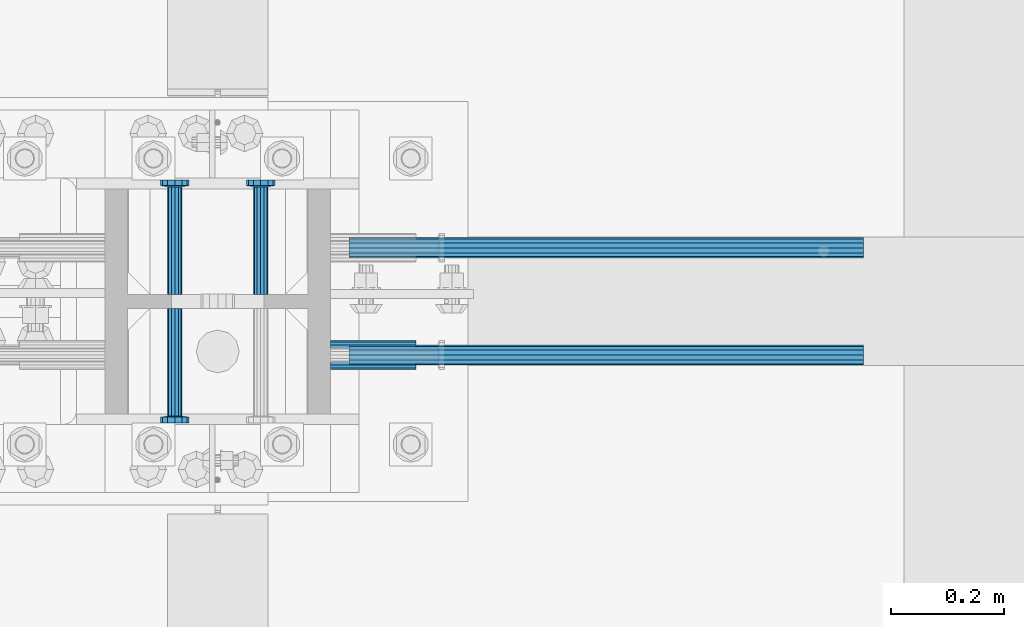
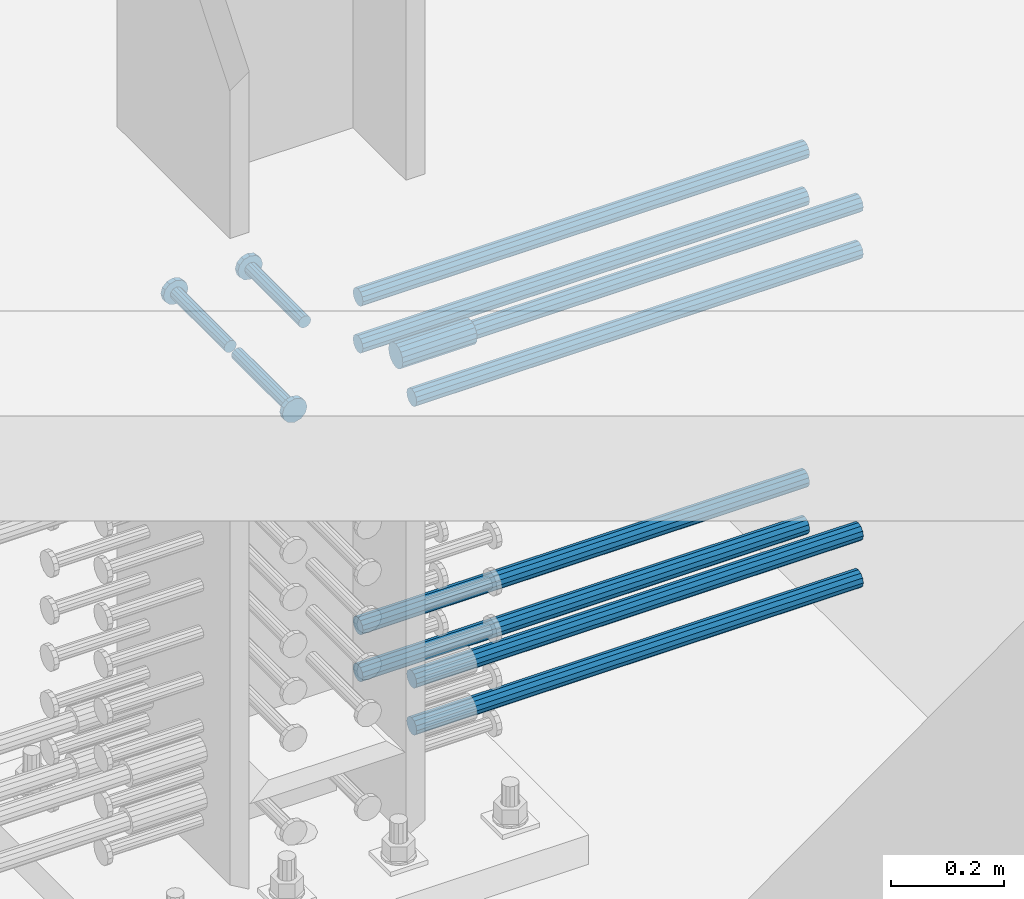
# One storey, part 1240 of 1763: 12 beams, 9 elements without a shape of their own.
"""IFC2X3 building model written with IfcOpenShell, lengths in millimetres."""

from ifc_helpers import new_model, si_unit, frame, origin_with_axes, place, context, subcontext, project, spatial, faceted_brep, material, type_object, element, aggregate, save


model = new_model("IFC2X3")

# Units and contexts
model_context = context("Model", 3, precision=1e-05, world=origin_with_axes())
body_context = subcontext(model_context, "Body", "Model", "MODEL_VIEW")
ifc_project = project(units=[si_unit("LENGTHUNIT", "METRE", prefix="MILLI"), si_unit("AREAUNIT", "SQUARE_METRE"), si_unit("VOLUMEUNIT", "CUBIC_METRE"), si_unit("MASSUNIT", "GRAM", prefix="KILO"), si_unit("TIMEUNIT", "SECOND"), si_unit("PLANEANGLEUNIT", "RADIAN"), si_unit("SOLIDANGLEUNIT", "STERADIAN"), si_unit("THERMODYNAMICTEMPERATUREUNIT", "DEGREE_CELSIUS"), si_unit("LUMINOUSINTENSITYUNIT", "LUMEN")], contexts=[model_context])

# Site, building, storey
site_placement = place(None, origin_with_axes())
site = spatial("IfcSite", under=ifc_project, at=site_placement, CompositionType="ELEMENT")
building_placement = place(site_placement, origin_with_axes())
building = spatial("IfcBuilding", under=site, at=building_placement, Name="Undefined", CompositionType="ELEMENT")
storey_placement = place(building_placement, origin_with_axes())
storey = spatial("IfcBuildingStorey", under=building, at=storey_placement, Name="Undefined", CompositionType="ELEMENT", Elevation=0.0)

# Assembly, beam
assembly_1_placement = place(storey_placement, origin_with_axes())
assembly_1 = element("IfcElementAssembly", 1, at=assembly_1_placement, inside=storey, Name="COLUMN", AssemblyPlace="NOTDEFINED", PredefinedType="RIGID_FRAME")
ifc_material_1 = material(Name="STEEL/A706-GR.80")
beam_type_1 = type_object("IfcBeamType", PredefinedType="NOTDEFINED")
beam_1_placement = place(assembly_1_placement, frame((-34749.812342359, 361.950000000843, 4876.80000000008), z_axis=(0.0, 0.0, 1.0), x_axis=(1.0, 0.0, 0.0)))
beam_1 = element("IfcBeam", 2, at=beam_1_placement, type_object=beam_type_1, material=ifc_material_1, Name="HALF COUPLER F", context=body_context, shape_type="Brep", body=[
    faceted_brep([(32.7659999999996, -8.95349999999962, -15.507916905568), (32.7659999999996, 0.0, -17.9070000000002), (32.7659999999996, 8.95349999999962, -15.507916905568), (32.7659999999996, 15.507916905568, -8.95350000000008), (32.7659999999996, 17.9069999999992, 0.0), (32.7659999999996, 15.507916905568, 8.95350000000008), (32.7659999999996, 8.95349999999962, 15.507916905568), (32.7659999999996, 0.0, 17.9070000000002), (32.7659999999996, -8.95349999999962, 15.507916905568), (32.7659999999996, -15.507916905568, 8.95350000000008), (32.7659999999996, -17.9069999999992, 0.0), (32.7659999999996, -15.507916905568, -8.95350000000008), (152.400103102711, -15.507916905568, 8.95350000000008), (152.400103102711, -8.95349999999962, 15.507916905568), (152.400103102711, -17.9069999999992, 0.0), (152.400103102711, -15.507916905568, -8.95350000000008), (152.400103102711, -8.95349999999962, -15.507916905568), (152.400103102711, 0.0, -17.9070000000002), (152.400103102711, 8.95349999999962, -15.507916905568), (152.400103102711, 15.507916905568, -8.95350000000008), (152.400103102711, 17.9069999999992, 0.0), (152.400103102711, 15.507916905568, 8.95350000000008), (152.400103102711, 8.95349999999962, 15.507916905568), (152.400103102711, 0.0, 17.9070000000002), (0.0, -23.466540125788, 9.72015918207308), (0.0, -17.9605122421381, 17.9605122421385), (0.0, -9.72015918207398, 23.4665401257867), (0.0, 0.0, 25.4000000000001), (0.0, 9.72015918207398, 23.4665401257867), (0.0, 17.9605122421381, 17.9605122421385), (0.0, 23.466540125788, 9.72015918207308), (0.0, 25.4000000000015, 0.0), (0.0, 23.466540125788, -9.72015918207308), (0.0, 17.9605122421381, -17.9605122421385), (0.0, 9.72015918207398, -23.4665401257867), (0.0, 0.0, -25.4000000000001), (0.0, -9.72015918207398, -23.4665401257867), (0.0, -17.9605122421381, -17.9605122421385), (0.0, -23.466540125788, -9.72015918207308), (0.0, -25.4000000000015, 0.0), (152.400103102711, -25.4000000000015, 0.0), (152.400103102711, -23.466540125788, 9.72015918207308), (152.400103102711, -17.9605122421381, 17.9605122421385), (152.400103102711, -9.72015918207398, 23.4665401257867), (152.400103102711, 0.0, 25.4000000000001), (152.400103102711, 9.72015918207398, 23.4665401257867), (152.400103102711, 17.9605122421381, 17.9605122421385), (152.400103102711, 23.466540125788, 9.72015918207308), (152.400103102711, 25.4000000000015, 0.0), (152.400103102711, 23.466540125788, -9.72015918207308), (152.400103102711, 17.9605122421381, -17.9605122421385), (152.400103102711, 9.72015918207398, -23.4665401257867), (152.400103102711, 0.0, -25.4000000000001), (152.400103102711, -9.72015918207398, -23.4665401257867), (152.400103102711, -17.9605122421381, -17.9605122421385), (152.400103102711, -23.466540125788, -9.72015918207308)], [[[0, 1, 2, 3, 4, 5, 6, 7, 8, 9, 10, 11]], [[12, 9, 8, 13]], [[14, 10, 9, 12]], [[15, 11, 10, 14]], [[16, 0, 11, 15]], [[17, 1, 0, 16]], [[18, 2, 1, 17]], [[19, 3, 2, 18]], [[20, 4, 3, 19]], [[21, 5, 4, 20]], [[22, 6, 5, 21]], [[23, 7, 6, 22]], [[13, 8, 7, 23]], [[24, 25, 26, 27, 28, 29, 30, 31, 32, 33, 34, 35, 36, 37, 38, 39]], [[24, 39, 40, 41]], [[25, 24, 41, 42]], [[26, 25, 42, 43]], [[27, 26, 43, 44]], [[28, 27, 44, 45]], [[29, 28, 45, 46]], [[30, 29, 46, 47]], [[31, 30, 47, 48]], [[32, 31, 48, 49]], [[33, 32, 49, 50]], [[34, 33, 50, 51]], [[35, 34, 51, 52]], [[36, 35, 52, 53]], [[37, 36, 53, 54]], [[38, 37, 54, 55]], [[39, 38, 55, 40]], [[54, 53, 52, 51, 50, 49, 48, 47, 46, 45, 44, 43, 42, 41, 40, 55], [21, 20, 19, 18, 17, 16, 15, 14, 12, 13, 23, 22]]]),
])

assembly_2_placement = place(storey_placement, origin_with_axes())
assembly_2 = element("IfcElementAssembly", 3, at=assembly_2_placement, inside=storey, Name="REBAR", AssemblyPlace="NOTDEFINED", PredefinedType="RIGID_FRAME")
beam_type_2 = type_object("IfcBeamType", Name="#11 REBAR", PredefinedType="NOTDEFINED")
beam_2_placement = place(assembly_2_placement, frame((-34717.0460129546, 361.949999998851, 4165.60000000003), z_axis=(0.0, 0.0, 1.0), x_axis=(1.0, 0.0, 0.0)))
beam_2 = element("IfcBeam", 4, at=beam_2_placement, type_object=beam_type_2, material=ifc_material_1, Name="REBAR", ObjectType="#11 REBAR", context=body_context, shape_type="Brep", body=[
    faceted_brep([(0.0, -17.9069999999992, 0.0), (0.0, -15.507916905568, -8.95349999999962), (914.400000001086, -15.507916905568, -8.95349999999962), (914.400000001086, -17.9069999999992, 0.0), (0.0, -8.95349999999962, -15.507916905568), (914.400000001086, -8.95349999999962, -15.507916905568), (0.0, 0.0, -17.9070000000002), (914.400000001086, 0.0, -17.9070000000002), (0.0, 8.95349999999962, -15.507916905568), (914.400000001086, 8.95349999999962, -15.507916905568), (0.0, 15.507916905568, -8.95349999999962), (914.400000001086, 15.507916905568, -8.95349999999962), (0.0, 17.9069999999992, 0.0), (914.400000001086, 17.9069999999992, 0.0), (0.0, 15.507916905568, 8.95349999999962), (914.400000001086, 15.507916905568, 8.95349999999962), (0.0, 8.95349999999962, 15.507916905568), (914.400000001086, 8.95349999999962, 15.507916905568), (0.0, 0.0, 17.9070000000002), (914.400000001086, 0.0, 17.9070000000002), (0.0, -8.95349999999962, 15.507916905568), (914.400000001086, -8.95349999999962, 15.507916905568), (0.0, -15.507916905568, 8.95349999999962), (914.400000001086, -15.507916905568, 8.95349999999962)], [[[0, 1, 2, 3]], [[1, 4, 5, 2]], [[4, 6, 7, 5]], [[6, 8, 9, 7]], [[8, 10, 11, 9]], [[10, 12, 13, 11]], [[12, 14, 15, 13]], [[14, 16, 17, 15]], [[16, 18, 19, 17]], [[18, 20, 21, 19]], [[20, 22, 23, 21]], [[22, 0, 3, 23]], [[5, 7, 9, 11, 13, 15, 17, 19, 21, 23, 3, 2]], [[22, 20, 18, 16, 14, 12, 10, 8, 6, 4, 1, 0]]]),
])
aggregate(assembly_2, [beam_2])

assembly_3_placement = place(storey_placement, origin_with_axes())
assembly_3 = element("IfcElementAssembly", 5, at=assembly_3_placement, inside=storey, Name="REBAR", AssemblyPlace="NOTDEFINED", PredefinedType="RIGID_FRAME")
beam_3_placement = place(assembly_3_placement, frame((-34717.0459442928, 552.449999998264, 4165.60000000003), z_axis=(0.0, 0.0, 1.0), x_axis=(1.0, 0.0, 0.0)))
beam_3 = element("IfcBeam", 6, at=beam_3_placement, type_object=beam_type_2, material=ifc_material_1, Name="REBAR", ObjectType="#11 REBAR", context=body_context, shape_type="Brep", body=[
    faceted_brep([(0.0, -17.9069999999992, 0.0), (0.0, -15.507916905568, -8.95349999999962), (914.400000001086, -15.507916905568, -8.95349999999962), (914.400000001086, -17.9069999999992, 0.0), (0.0, -8.95349999999962, -15.507916905568), (914.400000001086, -8.95349999999962, -15.507916905568), (0.0, 0.0, -17.9070000000002), (914.400000001086, 0.0, -17.9070000000002), (0.0, 8.95349999999962, -15.507916905568), (914.400000001086, 8.95349999999962, -15.507916905568), (0.0, 15.507916905568, -8.95349999999962), (914.400000001086, 15.507916905568, -8.95349999999962), (0.0, 17.9069999999992, 0.0), (914.400000001086, 17.9069999999992, 0.0), (0.0, 15.507916905568, 8.95349999999962), (914.400000001086, 15.507916905568, 8.95349999999962), (0.0, 8.95349999999962, 15.507916905568), (914.400000001086, 8.95349999999962, 15.507916905568), (0.0, 0.0, 17.9070000000002), (914.400000001086, 0.0, 17.9070000000002), (0.0, -8.95349999999962, 15.507916905568), (914.400000001086, -8.95349999999962, 15.507916905568), (0.0, -15.507916905568, 8.95349999999962), (914.400000001086, -15.507916905568, 8.95349999999962)], [[[0, 1, 2, 3]], [[1, 4, 5, 2]], [[4, 6, 7, 5]], [[6, 8, 9, 7]], [[8, 10, 11, 9]], [[10, 12, 13, 11]], [[12, 14, 15, 13]], [[14, 16, 17, 15]], [[16, 18, 19, 17]], [[18, 20, 21, 19]], [[20, 22, 23, 21]], [[22, 0, 3, 23]], [[5, 7, 9, 11, 13, 15, 17, 19, 21, 23, 3, 2]], [[22, 20, 18, 16, 14, 12, 10, 8, 6, 4, 1, 0]]]),
])
aggregate(assembly_3, [beam_3])

assembly_4_placement = place(storey_placement, origin_with_axes())
assembly_4 = element("IfcElementAssembly", 7, at=assembly_4_placement, inside=storey, Name="REBAR", AssemblyPlace="NOTDEFINED", PredefinedType="RIGID_FRAME")
beam_4_placement = place(assembly_4_placement, frame((-34717.0460129546, 361.949999998855, 4064.00000000003), z_axis=(0.0, 0.0, 1.0), x_axis=(1.0, 0.0, 0.0)))
beam_4 = element("IfcBeam", 8, at=beam_4_placement, type_object=beam_type_2, material=ifc_material_1, Name="REBAR", ObjectType="#11 REBAR", context=body_context, shape_type="Brep", body=[
    faceted_brep([(0.0, -17.9069999999992, 0.0), (0.0, -15.507916905568, -8.95349999999962), (914.400000001086, -15.507916905568, -8.95349999999962), (914.400000001086, -17.9069999999992, 0.0), (0.0, -8.95349999999962, -15.507916905568), (914.400000001086, -8.95349999999962, -15.507916905568), (0.0, 0.0, -17.9070000000002), (914.400000001086, 0.0, -17.9070000000002), (0.0, 8.95349999999962, -15.507916905568), (914.400000001086, 8.95349999999962, -15.507916905568), (0.0, 15.507916905568, -8.95349999999962), (914.400000001086, 15.507916905568, -8.95349999999962), (0.0, 17.9069999999992, 0.0), (914.400000001086, 17.9069999999992, 0.0), (0.0, 15.507916905568, 8.95349999999962), (914.400000001086, 15.507916905568, 8.95349999999962), (0.0, 8.95349999999962, 15.507916905568), (914.400000001086, 8.95349999999962, 15.507916905568), (0.0, 0.0, 17.9070000000002), (914.400000001086, 0.0, 17.9070000000002), (0.0, -8.95349999999962, 15.507916905568), (914.400000001086, -8.95349999999962, 15.507916905568), (0.0, -15.507916905568, 8.95349999999962), (914.400000001086, -15.507916905568, 8.95349999999962)], [[[0, 1, 2, 3]], [[1, 4, 5, 2]], [[4, 6, 7, 5]], [[6, 8, 9, 7]], [[8, 10, 11, 9]], [[10, 12, 13, 11]], [[12, 14, 15, 13]], [[14, 16, 17, 15]], [[16, 18, 19, 17]], [[18, 20, 21, 19]], [[20, 22, 23, 21]], [[22, 0, 3, 23]], [[5, 7, 9, 11, 13, 15, 17, 19, 21, 23, 3, 2]], [[22, 20, 18, 16, 14, 12, 10, 8, 6, 4, 1, 0]]]),
])
aggregate(assembly_4, [beam_4])

assembly_5_placement = place(storey_placement, origin_with_axes())
assembly_5 = element("IfcElementAssembly", 9, at=assembly_5_placement, inside=storey, Name="REBAR", AssemblyPlace="NOTDEFINED", PredefinedType="RIGID_FRAME")
beam_5_placement = place(assembly_5_placement, frame((-34717.0459442928, 552.449999998267, 4064.00000000003), z_axis=(0.0, 0.0, 1.0), x_axis=(1.0, 0.0, 0.0)))
beam_5 = element("IfcBeam", 10, at=beam_5_placement, type_object=beam_type_2, material=ifc_material_1, Name="REBAR", ObjectType="#11 REBAR", context=body_context, shape_type="Brep", body=[
    faceted_brep([(0.0, -17.9069999999992, 0.0), (0.0, -15.507916905568, -8.95349999999962), (914.400000001086, -15.507916905568, -8.95349999999962), (914.400000001086, -17.9069999999992, 0.0), (0.0, -8.95349999999962, -15.507916905568), (914.400000001086, -8.95349999999962, -15.507916905568), (0.0, 0.0, -17.9070000000002), (914.400000001086, 0.0, -17.9070000000002), (0.0, 8.95349999999962, -15.507916905568), (914.400000001086, 8.95349999999962, -15.507916905568), (0.0, 15.507916905568, -8.95349999999962), (914.400000001086, 15.507916905568, -8.95349999999962), (0.0, 17.9069999999992, 0.0), (914.400000001086, 17.9069999999992, 0.0), (0.0, 15.507916905568, 8.95349999999962), (914.400000001086, 15.507916905568, 8.95349999999962), (0.0, 8.95349999999962, 15.507916905568), (914.400000001086, 8.95349999999962, 15.507916905568), (0.0, 0.0, 17.9070000000002), (914.400000001086, 0.0, 17.9070000000002), (0.0, -8.95349999999962, 15.507916905568), (914.400000001086, -8.95349999999962, 15.507916905568), (0.0, -15.507916905568, 8.95349999999962), (914.400000001086, -15.507916905568, 8.95349999999962)], [[[0, 1, 2, 3]], [[1, 4, 5, 2]], [[4, 6, 7, 5]], [[6, 8, 9, 7]], [[8, 10, 11, 9]], [[10, 12, 13, 11]], [[12, 14, 15, 13]], [[14, 16, 17, 15]], [[16, 18, 19, 17]], [[18, 20, 21, 19]], [[20, 22, 23, 21]], [[22, 0, 3, 23]], [[5, 7, 9, 11, 13, 15, 17, 19, 21, 23, 3, 2]], [[22, 20, 18, 16, 14, 12, 10, 8, 6, 4, 1, 0]]]),
])
aggregate(assembly_5, [beam_5])

assembly_6_placement = place(storey_placement, origin_with_axes())
assembly_6 = element("IfcElementAssembly", 11, at=assembly_6_placement, inside=storey, Name="REBAR", AssemblyPlace="NOTDEFINED", PredefinedType="RIGID_FRAME")
beam_6_placement = place(assembly_6_placement, frame((-34717.0460816901, 361.949999998849, 4876.80000000009), z_axis=(0.0, 0.0, 1.0), x_axis=(1.0, 0.0, 0.0)))
beam_6 = element("IfcBeam", 12, at=beam_6_placement, type_object=beam_type_2, material=ifc_material_1, Name="REBAR", ObjectType="#11 REBAR", context=body_context, shape_type="Brep", body=[
    faceted_brep([(0.0, -17.9069999999992, 0.0), (0.0, -15.507916905568, -8.95349999999962), (914.400000001086, -15.507916905568, -8.95349999999962), (914.400000001086, -17.9069999999992, 0.0), (0.0, -8.95349999999962, -15.507916905568), (914.400000001086, -8.95349999999962, -15.507916905568), (0.0, 0.0, -17.9070000000002), (914.400000001086, 0.0, -17.9070000000002), (0.0, 8.95349999999962, -15.507916905568), (914.400000001086, 8.95349999999962, -15.507916905568), (0.0, 15.507916905568, -8.95349999999962), (914.400000001086, 15.507916905568, -8.95349999999962), (0.0, 17.9069999999992, 0.0), (914.400000001086, 17.9069999999992, 0.0), (0.0, 15.507916905568, 8.95349999999962), (914.400000001086, 15.507916905568, 8.95349999999962), (0.0, 8.95349999999962, 15.507916905568), (914.400000001086, 8.95349999999962, 15.507916905568), (0.0, 0.0, 17.9070000000002), (914.400000001086, 0.0, 17.9070000000002), (0.0, -8.95349999999962, 15.507916905568), (914.400000001086, -8.95349999999962, 15.507916905568), (0.0, -15.507916905568, 8.95349999999962), (914.400000001086, -15.507916905568, 8.95349999999962)], [[[0, 1, 2, 3]], [[1, 4, 5, 2]], [[4, 6, 7, 5]], [[6, 8, 9, 7]], [[8, 10, 11, 9]], [[10, 12, 13, 11]], [[12, 14, 15, 13]], [[14, 16, 17, 15]], [[16, 18, 19, 17]], [[18, 20, 21, 19]], [[20, 22, 23, 21]], [[22, 0, 3, 23]], [[5, 7, 9, 11, 13, 15, 17, 19, 21, 23, 3, 2]], [[22, 20, 18, 16, 14, 12, 10, 8, 6, 4, 1, 0]]]),
])
aggregate(assembly_6, [beam_6])

assembly_7_placement = place(storey_placement, origin_with_axes())
assembly_7 = element("IfcElementAssembly", 13, at=assembly_7_placement, inside=storey, Name="REBAR", AssemblyPlace="NOTDEFINED", PredefinedType="RIGID_FRAME")
beam_7_placement = place(assembly_7_placement, frame((-34717.0460130289, 552.449999998262, 4876.80000000009), z_axis=(0.0, 0.0, 1.0), x_axis=(1.0, 0.0, 0.0)))
beam_7 = element("IfcBeam", 14, at=beam_7_placement, type_object=beam_type_2, material=ifc_material_1, Name="REBAR", ObjectType="#11 REBAR", context=body_context, shape_type="Brep", body=[
    faceted_brep([(0.0, -17.9069999999992, 0.0), (0.0, -15.507916905568, -8.95349999999962), (914.400000001086, -15.507916905568, -8.95349999999962), (914.400000001086, -17.9069999999992, 0.0), (0.0, -8.95349999999962, -15.507916905568), (914.400000001086, -8.95349999999962, -15.507916905568), (0.0, 0.0, -17.9070000000002), (914.400000001086, 0.0, -17.9070000000002), (0.0, 8.95349999999962, -15.507916905568), (914.400000001086, 8.95349999999962, -15.507916905568), (0.0, 15.507916905568, -8.95349999999962), (914.400000001086, 15.507916905568, -8.95349999999962), (0.0, 17.9069999999992, 0.0), (914.400000001086, 17.9069999999992, 0.0), (0.0, 15.507916905568, 8.95349999999962), (914.400000001086, 15.507916905568, 8.95349999999962), (0.0, 8.95349999999962, 15.507916905568), (914.400000001086, 8.95349999999962, 15.507916905568), (0.0, 0.0, 17.9070000000002), (914.400000001086, 0.0, 17.9070000000002), (0.0, -8.95349999999962, 15.507916905568), (914.400000001086, -8.95349999999962, 15.507916905568), (0.0, -15.507916905568, 8.95349999999962), (914.400000001086, -15.507916905568, 8.95349999999962)], [[[0, 1, 2, 3]], [[1, 4, 5, 2]], [[4, 6, 7, 5]], [[6, 8, 9, 7]], [[8, 10, 11, 9]], [[10, 12, 13, 11]], [[12, 14, 15, 13]], [[14, 16, 17, 15]], [[16, 18, 19, 17]], [[18, 20, 21, 19]], [[20, 22, 23, 21]], [[22, 0, 3, 23]], [[5, 7, 9, 11, 13, 15, 17, 19, 21, 23, 3, 2]], [[22, 20, 18, 16, 14, 12, 10, 8, 6, 4, 1, 0]]]),
])
aggregate(assembly_7, [beam_7])

assembly_8_placement = place(storey_placement, origin_with_axes())
assembly_8 = element("IfcElementAssembly", 15, at=assembly_8_placement, inside=storey, Name="REBAR", AssemblyPlace="NOTDEFINED", PredefinedType="RIGID_FRAME")
beam_8_placement = place(assembly_8_placement, frame((-34717.0460816901, 361.949999998853, 4775.20000000009), z_axis=(0.0, 0.0, 1.0), x_axis=(1.0, 0.0, 0.0)))
beam_8 = element("IfcBeam", 16, at=beam_8_placement, type_object=beam_type_2, material=ifc_material_1, Name="REBAR", ObjectType="#11 REBAR", context=body_context, shape_type="Brep", body=[
    faceted_brep([(0.0, -17.9069999999992, 0.0), (0.0, -15.507916905568, -8.95349999999962), (914.400000001086, -15.507916905568, -8.95349999999962), (914.400000001086, -17.9069999999992, 0.0), (0.0, -8.95349999999962, -15.507916905568), (914.400000001086, -8.95349999999962, -15.507916905568), (0.0, 0.0, -17.9070000000002), (914.400000001086, 0.0, -17.9070000000002), (0.0, 8.95349999999962, -15.507916905568), (914.400000001086, 8.95349999999962, -15.507916905568), (0.0, 15.507916905568, -8.95349999999962), (914.400000001086, 15.507916905568, -8.95349999999962), (0.0, 17.9069999999992, 0.0), (914.400000001086, 17.9069999999992, 0.0), (0.0, 15.507916905568, 8.95349999999962), (914.400000001086, 15.507916905568, 8.95349999999962), (0.0, 8.95349999999962, 15.507916905568), (914.400000001086, 8.95349999999962, 15.507916905568), (0.0, 0.0, 17.9070000000002), (914.400000001086, 0.0, 17.9070000000002), (0.0, -8.95349999999962, 15.507916905568), (914.400000001086, -8.95349999999962, 15.507916905568), (0.0, -15.507916905568, 8.95349999999962), (914.400000001086, -15.507916905568, 8.95349999999962)], [[[0, 1, 2, 3]], [[1, 4, 5, 2]], [[4, 6, 7, 5]], [[6, 8, 9, 7]], [[8, 10, 11, 9]], [[10, 12, 13, 11]], [[12, 14, 15, 13]], [[14, 16, 17, 15]], [[16, 18, 19, 17]], [[18, 20, 21, 19]], [[20, 22, 23, 21]], [[22, 0, 3, 23]], [[5, 7, 9, 11, 13, 15, 17, 19, 21, 23, 3, 2]], [[22, 20, 18, 16, 14, 12, 10, 8, 6, 4, 1, 0]]]),
])
aggregate(assembly_8, [beam_8])

assembly_9_placement = place(storey_placement, origin_with_axes())
assembly_9 = element("IfcElementAssembly", 17, at=assembly_9_placement, inside=storey, Name="REBAR", AssemblyPlace="NOTDEFINED", PredefinedType="RIGID_FRAME")
beam_9_placement = place(assembly_9_placement, frame((-34717.0460130289, 552.449999998265, 4775.20000000009), z_axis=(0.0, 0.0, 1.0), x_axis=(1.0, 0.0, 0.0)))
beam_9 = element("IfcBeam", 18, at=beam_9_placement, type_object=beam_type_2, material=ifc_material_1, Name="REBAR", ObjectType="#11 REBAR", context=body_context, shape_type="Brep", body=[
    faceted_brep([(0.0, -17.9069999999992, 0.0), (0.0, -15.507916905568, -8.95349999999962), (914.400000001086, -15.507916905568, -8.95349999999962), (914.400000001086, -17.9069999999992, 0.0), (0.0, -8.95349999999962, -15.507916905568), (914.400000001086, -8.95349999999962, -15.507916905568), (0.0, 0.0, -17.9070000000002), (914.400000001086, 0.0, -17.9070000000002), (0.0, 8.95349999999962, -15.507916905568), (914.400000001086, 8.95349999999962, -15.507916905568), (0.0, 15.507916905568, -8.95349999999962), (914.400000001086, 15.507916905568, -8.95349999999962), (0.0, 17.9069999999992, 0.0), (914.400000001086, 17.9069999999992, 0.0), (0.0, 15.507916905568, 8.95349999999962), (914.400000001086, 15.507916905568, 8.95349999999962), (0.0, 8.95349999999962, 15.507916905568), (914.400000001086, 8.95349999999962, 15.507916905568), (0.0, 0.0, 17.9070000000002), (914.400000001086, 0.0, 17.9070000000002), (0.0, -8.95349999999962, 15.507916905568), (914.400000001086, -8.95349999999962, 15.507916905568), (0.0, -15.507916905568, 8.95349999999962), (914.400000001086, -15.507916905568, 8.95349999999962)], [[[0, 1, 2, 3]], [[1, 4, 5, 2]], [[4, 6, 7, 5]], [[6, 8, 9, 7]], [[8, 10, 11, 9]], [[10, 12, 13, 11]], [[12, 14, 15, 13]], [[14, 16, 17, 15]], [[16, 18, 19, 17]], [[18, 20, 21, 19]], [[20, 22, 23, 21]], [[22, 0, 3, 23]], [[5, 7, 9, 11, 13, 15, 17, 19, 21, 23, 3, 2]], [[22, 20, 18, 16, 14, 12, 10, 8, 6, 4, 1, 0]]]),
])
aggregate(assembly_9, [beam_9])

# Beam
ifc_material_2 = material(Name="STEEL/A108")
beam_type_3 = type_object("IfcBeamType", PredefinedType="NOTDEFINED")
beam_10_placement = place(assembly_1_placement, frame((-34873.6374118352, 469.899999999951, 4927.60000000008), z_axis=(1.0, 0.0, 0.0), x_axis=(0.0, 1.0, 0.0)))
beam_10 = element("IfcBeam", 19, at=beam_10_placement, type_object=beam_type_3, material=ifc_material_2, Name="HEADED STUD ANCHOR", context=body_context, shape_type="Brep", body=[
    faceted_brep([(0.0, -12.6999999999971, -1.81898940354586e-12), (3.63797880709171e-12, -11.0, -6.34999990463257), (191.00799999576, -11.0, -6.34999990454889), (191.007999995752, -12.6999998092651, 8.36735125631094e-11), (7.27595761418343e-12, -6.34999990463257, -11.0), (191.00799999576, -6.34999990463257, -10.9999999999163), (3.63797880709171e-12, 0.0, -12.6999998092651), (191.00799999576, 0.0, -12.6999998091815), (7.27595761418343e-12, 6.34999990463257, -11.0), (191.00799999576, 6.34999990463257, -10.9999999999163), (3.63797880709171e-12, 11.0, -6.34999990463257), (191.00799999576, 11.0, -6.34999990454889), (0.0, 12.6999999999971, -1.81898940354586e-12), (191.007999995752, 12.6999998092651, 8.36735125631094e-11), (0.0, 11.0, 6.34999990463257), (191.007999995752, 11.0, 6.34999990471624), (-3.63797880709171e-12, 6.34999990463257, 11.0), (191.007999995749, 6.34999990463257, 11.0000000000837), (-3.63797880709171e-12, 0.0, 12.6999998092651), (191.007999995749, 0.0, 12.6999998093488), (-3.63797880709171e-12, -6.34999990463257, 11.0), (191.007999995749, -6.34999990463257, 11.0000000000837), (0.0, -11.0, 6.34999990463257), (191.007999995752, -11.0, 6.34999990471624), (193.039999995715, -22.0, -12.6999998091796), (193.039999995708, -25.3999996185303, 8.54925019666553e-11), (193.039999995719, -12.6999998092651, -21.9999999999145), (193.039999995719, 0.0, -25.3999996184448), (193.039999995719, 12.6999998092651, -21.9999999999145), (193.039999995715, 22.0, -12.6999998091796), (193.039999995708, 25.3999996185303, 8.54925019666553e-11), (193.039999995704, 22.0, 12.6999998093506), (193.039999995701, 12.6999998092651, 22.0000000000855), (193.039999995697, 0.0, 25.3999996186158), (193.039999995701, -12.6999998092651, 22.0000000000855), (193.039999995704, -22.0, 12.6999998093506), (203.199999995486, -22.0, -12.6999998091742), (203.199999995482, -25.3999996185303, 9.09494701772928e-11), (203.199999995493, -12.6999998092651, -21.9999999999091), (203.199999995493, 0.0, -25.3999996184393), (203.199999995493, 12.6999998092651, -21.9999999999091), (203.199999995486, 22.0, -12.6999998091742), (203.199999995482, 25.3999996185303, 9.09494701772928e-11), (203.199999995479, 22.0, 12.6999998093561), (203.199999995475, 12.6999998092651, 22.0000000000909), (203.199999995471, 0.0, 25.3999996186212), (203.199999995475, -12.6999998092651, 22.0000000000909), (203.199999995479, -22.0, 12.6999998093561)], [[[0, 1, 2, 3]], [[1, 4, 5, 2]], [[4, 6, 7, 5]], [[6, 8, 9, 7]], [[8, 10, 11, 9]], [[10, 12, 13, 11]], [[12, 14, 15, 13]], [[14, 16, 17, 15]], [[16, 18, 19, 17]], [[18, 20, 21, 19]], [[20, 22, 23, 21]], [[22, 0, 3, 23]], [[22, 20, 18, 16, 14, 12, 10, 8, 6, 4, 1, 0]], [[3, 2, 24, 25]], [[2, 5, 26, 24]], [[5, 7, 27, 26]], [[7, 9, 28, 27]], [[9, 11, 29, 28]], [[11, 13, 30, 29]], [[13, 15, 31, 30]], [[15, 17, 32, 31]], [[17, 19, 33, 32]], [[19, 21, 34, 33]], [[21, 23, 35, 34]], [[23, 3, 25, 35]], [[25, 24, 36, 37]], [[24, 26, 38, 36]], [[26, 27, 39, 38]], [[27, 28, 40, 39]], [[28, 29, 41, 40]], [[29, 30, 42, 41]], [[30, 31, 43, 42]], [[31, 32, 44, 43]], [[32, 33, 45, 44]], [[33, 34, 46, 45]], [[34, 35, 47, 46]], [[35, 25, 37, 47]], [[38, 39, 40, 41, 42, 43, 44, 45, 46, 47, 37, 36]]]),
])

beam_11_placement = place(assembly_1_placement, frame((-35026.037411835, 469.89999900281, 4927.60000000008), z_axis=(1.0, 0.0, 0.0), x_axis=(0.0, 1.0, 0.0)))
beam_11 = element("IfcBeam", 20, at=beam_11_placement, type_object=beam_type_3, material=ifc_material_2, Name="HEADED STUD ANCHOR", context=body_context, shape_type="Brep", body=[
    faceted_brep([(0.0, -12.6999999999971, -1.81898940354586e-12), (3.63797880709171e-12, -11.0, -6.34999990463257), (191.00799999576, -11.0, -6.34999990454889), (191.007999995752, -12.6999998092651, 8.36735125631094e-11), (7.27595761418343e-12, -6.34999990463257, -11.0), (191.00799999576, -6.34999990463257, -10.9999999999163), (3.63797880709171e-12, 0.0, -12.6999998092651), (191.00799999576, 0.0, -12.6999998091815), (7.27595761418343e-12, 6.34999990463257, -11.0), (191.00799999576, 6.34999990463257, -10.9999999999163), (3.63797880709171e-12, 11.0, -6.34999990463257), (191.00799999576, 11.0, -6.34999990454889), (0.0, 12.6999999999971, -1.81898940354586e-12), (191.007999995752, 12.6999998092651, 8.36735125631094e-11), (0.0, 11.0, 6.34999990463257), (191.007999995752, 11.0, 6.34999990471624), (-3.63797880709171e-12, 6.34999990463257, 11.0), (191.007999995749, 6.34999990463257, 11.0000000000837), (-3.63797880709171e-12, 0.0, 12.6999998092651), (191.007999995749, 0.0, 12.6999998093488), (-3.63797880709171e-12, -6.34999990463257, 11.0), (191.007999995749, -6.34999990463257, 11.0000000000837), (0.0, -11.0, 6.34999990463257), (191.007999995752, -11.0, 6.34999990471624), (193.039999995715, -22.0, -12.6999998091796), (193.039999995708, -25.3999996185303, 8.54925019666553e-11), (193.039999995719, -12.6999998092651, -21.9999999999145), (193.039999995719, 0.0, -25.3999996184448), (193.039999995719, 12.6999998092651, -21.9999999999145), (193.039999995715, 22.0, -12.6999998091796), (193.039999995708, 25.3999996185303, 8.54925019666553e-11), (193.039999995704, 22.0, 12.6999998093506), (193.039999995701, 12.6999998092651, 22.0000000000855), (193.039999995697, 0.0, 25.3999996186158), (193.039999995701, -12.6999998092651, 22.0000000000855), (193.039999995704, -22.0, 12.6999998093506), (203.199999995486, -22.0, -12.6999998091742), (203.199999995482, -25.3999996185303, 9.09494701772928e-11), (203.199999995493, -12.6999998092651, -21.9999999999091), (203.199999995493, 0.0, -25.3999996184393), (203.199999995493, 12.6999998092651, -21.9999999999091), (203.199999995486, 22.0, -12.6999998091742), (203.199999995482, 25.3999996185303, 9.09494701772928e-11), (203.199999995479, 22.0, 12.6999998093561), (203.199999995475, 12.6999998092651, 22.0000000000909), (203.199999995471, 0.0, 25.3999996186212), (203.199999995475, -12.6999998092651, 22.0000000000909), (203.199999995479, -22.0, 12.6999998093561)], [[[0, 1, 2, 3]], [[1, 4, 5, 2]], [[4, 6, 7, 5]], [[6, 8, 9, 7]], [[8, 10, 11, 9]], [[10, 12, 13, 11]], [[12, 14, 15, 13]], [[14, 16, 17, 15]], [[16, 18, 19, 17]], [[18, 20, 21, 19]], [[20, 22, 23, 21]], [[22, 0, 3, 23]], [[22, 20, 18, 16, 14, 12, 10, 8, 6, 4, 1, 0]], [[3, 2, 24, 25]], [[2, 5, 26, 24]], [[5, 7, 27, 26]], [[7, 9, 28, 27]], [[9, 11, 29, 28]], [[11, 13, 30, 29]], [[13, 15, 31, 30]], [[15, 17, 32, 31]], [[17, 19, 33, 32]], [[19, 21, 34, 33]], [[21, 23, 35, 34]], [[23, 3, 25, 35]], [[25, 24, 36, 37]], [[24, 26, 38, 36]], [[26, 27, 39, 38]], [[27, 28, 40, 39]], [[28, 29, 41, 40]], [[29, 30, 42, 41]], [[30, 31, 43, 42]], [[31, 32, 44, 43]], [[32, 33, 45, 44]], [[33, 34, 46, 45]], [[34, 35, 47, 46]], [[35, 25, 37, 47]], [[38, 39, 40, 41, 42, 43, 44, 45, 46, 47, 37, 36]]]),
])

beam_12_placement = place(assembly_1_placement, frame((-35026.0374108265, 444.499999885675, 4927.60000000008), z_axis=(1.0, 0.0, 0.0), x_axis=(0.0, -1.0, 0.0)))
beam_12 = element("IfcBeam", 21, at=beam_12_placement, type_object=beam_type_3, material=ifc_material_2, Name="HEADED STUD ANCHOR", context=body_context, shape_type="Brep", body=[
    faceted_brep([(0.0, -12.6999999999971, -1.81898940354586e-12), (3.63797880709171e-12, -11.0, -6.34999990463257), (191.00799999576, -11.0, -6.34999990454889), (191.007999995752, -12.6999998092651, 8.36735125631094e-11), (7.27595761418343e-12, -6.34999990463257, -11.0), (191.00799999576, -6.34999990463257, -10.9999999999163), (3.63797880709171e-12, 0.0, -12.6999998092651), (191.00799999576, 0.0, -12.6999998091815), (7.27595761418343e-12, 6.34999990463257, -11.0), (191.00799999576, 6.34999990463257, -10.9999999999163), (3.63797880709171e-12, 11.0, -6.34999990463257), (191.00799999576, 11.0, -6.34999990454889), (0.0, 12.6999999999971, -1.81898940354586e-12), (191.007999995752, 12.6999998092651, 8.36735125631094e-11), (0.0, 11.0, 6.34999990463257), (191.007999995752, 11.0, 6.34999990471624), (-3.63797880709171e-12, 6.34999990463257, 11.0), (191.007999995749, 6.34999990463257, 11.0000000000837), (-3.63797880709171e-12, 0.0, 12.6999998092651), (191.007999995749, 0.0, 12.6999998093488), (-3.63797880709171e-12, -6.34999990463257, 11.0), (191.007999995749, -6.34999990463257, 11.0000000000837), (0.0, -11.0, 6.34999990463257), (191.007999995752, -11.0, 6.34999990471624), (193.039999995715, -22.0, -12.6999998091796), (193.039999995708, -25.3999996185303, 8.54925019666553e-11), (193.039999995719, -12.6999998092651, -21.9999999999145), (193.039999995719, 0.0, -25.3999996184448), (193.039999995719, 12.6999998092651, -21.9999999999145), (193.039999995715, 22.0, -12.6999998091796), (193.039999995708, 25.3999996185303, 8.54925019666553e-11), (193.039999995704, 22.0, 12.6999998093506), (193.039999995701, 12.6999998092651, 22.0000000000855), (193.039999995697, 0.0, 25.3999996186158), (193.039999995701, -12.6999998092651, 22.0000000000855), (193.039999995704, -22.0, 12.6999998093506), (203.199999995486, -22.0, -12.6999998091742), (203.199999995482, -25.3999996185303, 9.09494701772928e-11), (203.199999995493, -12.6999998092651, -21.9999999999091), (203.199999995493, 0.0, -25.3999996184393), (203.199999995493, 12.6999998092651, -21.9999999999091), (203.199999995486, 22.0, -12.6999998091742), (203.199999995482, 25.3999996185303, 9.09494701772928e-11), (203.199999995479, 22.0, 12.6999998093561), (203.199999995475, 12.6999998092651, 22.0000000000909), (203.199999995471, 0.0, 25.3999996186212), (203.199999995475, -12.6999998092651, 22.0000000000909), (203.199999995479, -22.0, 12.6999998093561)], [[[0, 1, 2, 3]], [[1, 4, 5, 2]], [[4, 6, 7, 5]], [[6, 8, 9, 7]], [[8, 10, 11, 9]], [[10, 12, 13, 11]], [[12, 14, 15, 13]], [[14, 16, 17, 15]], [[16, 18, 19, 17]], [[18, 20, 21, 19]], [[20, 22, 23, 21]], [[22, 0, 3, 23]], [[22, 20, 18, 16, 14, 12, 10, 8, 6, 4, 1, 0]], [[3, 2, 24, 25]], [[2, 5, 26, 24]], [[5, 7, 27, 26]], [[7, 9, 28, 27]], [[9, 11, 29, 28]], [[11, 13, 30, 29]], [[13, 15, 31, 30]], [[15, 17, 32, 31]], [[17, 19, 33, 32]], [[19, 21, 34, 33]], [[21, 23, 35, 34]], [[23, 3, 25, 35]], [[25, 24, 36, 37]], [[24, 26, 38, 36]], [[26, 27, 39, 38]], [[27, 28, 40, 39]], [[28, 29, 41, 40]], [[29, 30, 42, 41]], [[30, 31, 43, 42]], [[31, 32, 44, 43]], [[32, 33, 45, 44]], [[33, 34, 46, 45]], [[34, 35, 47, 46]], [[35, 25, 37, 47]], [[38, 39, 40, 41, 42, 43, 44, 45, 46, 47, 37, 36]]]),
])

aggregate(assembly_1, [beam_1, beam_10, beam_11, beam_12])

save(model, "model.ifc")
